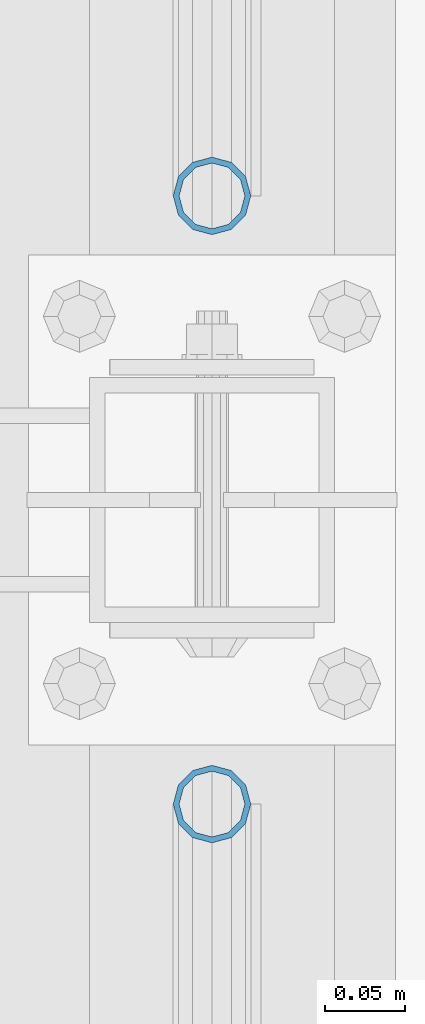
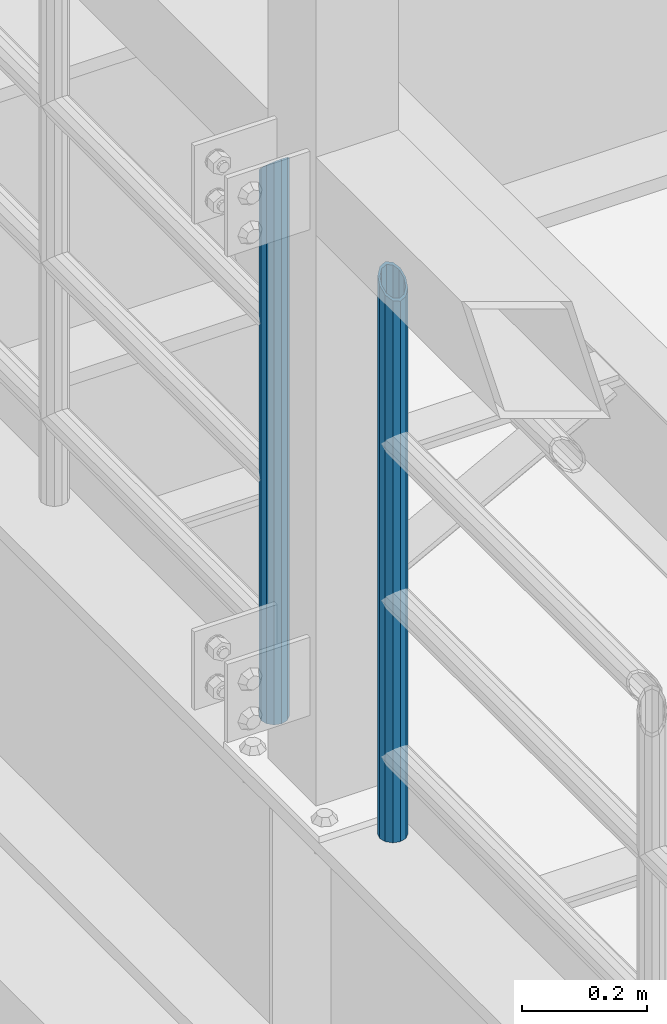
# One storey, part 681 of 1876: 2 columns, 2 elements without a shape of their own.
"""IFC2X3 building model written with IfcOpenShell, lengths in millimetres."""

from ifc_helpers import new_model, si_unit, frame, origin_with_axes, place, context, subcontext, project, spatial, faceted_brep, material, type_object, element, aggregate, save


model = new_model("IFC2X3")

# Units and contexts
model_context = context("Model", 3, precision=1e-05, world=origin_with_axes())
body_context = subcontext(model_context, "Body", "Model", "MODEL_VIEW")
ifc_project = project(units=[si_unit("LENGTHUNIT", "METRE", prefix="MILLI"), si_unit("AREAUNIT", "SQUARE_METRE"), si_unit("VOLUMEUNIT", "CUBIC_METRE"), si_unit("MASSUNIT", "GRAM", prefix="KILO"), si_unit("TIMEUNIT", "SECOND"), si_unit("PLANEANGLEUNIT", "RADIAN"), si_unit("SOLIDANGLEUNIT", "STERADIAN"), si_unit("THERMODYNAMICTEMPERATUREUNIT", "DEGREE_CELSIUS"), si_unit("LUMINOUSINTENSITYUNIT", "LUMEN")], contexts=[model_context])

# Site, building, storey
site_placement = place(None, origin_with_axes())
site = spatial("IfcSite", under=ifc_project, at=site_placement, CompositionType="ELEMENT")
building_placement = place(site_placement, origin_with_axes())
building = spatial("IfcBuilding", under=site, at=building_placement, Name="Undefined", CompositionType="ELEMENT")
storey_placement = place(building_placement, origin_with_axes())
storey = spatial("IfcBuildingStorey", under=building, at=storey_placement, Name="Undefined", CompositionType="ELEMENT", Elevation=0.0)

# Assembly, column
assembly_1_placement = place(storey_placement, origin_with_axes())
assembly_1 = element("IfcElementAssembly", 1, at=assembly_1_placement, inside=storey, Name="RAIL", AssemblyPlace="NOTDEFINED", PredefinedType="RIGID_FRAME")
ifc_material = material()
column_type = type_object("IfcColumnType", Name="PIPE1-1/2SCH40", PredefinedType="NOTDEFINED")
column_1_placement = place(assembly_1_placement, frame((-1.81898940354586e-12, -318.77, 5130.8), z_axis=(0.0, 1.0, 0.0), x_axis=(0.0, 0.0, 1.0)))
column_1 = element("IfcColumn", 2, at=column_1_placement, type_object=column_type, material=ifc_material, Name="POST", ObjectType="PIPE1-1/2SCH40", context=body_context, shape_type="Brep", body=[
    faceted_brep([(0.0, -20.4469999999999, 0.0), (0.0, -17.7076214311803, 10.2235000000001), (1066.10158618498, -17.7076214311801, 10.2235000000001), (1076.325, -20.4469999999999, 0.0), (0.0, -10.2235000000001, 17.7076214311801), (1058.61752784562, -10.2235000000001, 17.7076214311801), (-1.45519152283669e-11, 0.0, 20.4470000000001), (1055.87817237002, 0.0, 20.4470000000001), (0.0, 10.2235000000001, 17.7076214311801), (1058.61752784562, 10.2235000000001, 17.7076214311801), (0.0, 17.7076214311803, 10.2235000000001), (1066.10158618498, 17.7076214311801, 10.2235000000001), (0.0, 20.4469999999999, 0.0), (1076.325, 20.4469999999999, 0.0), (0.0, 17.7076214311803, -10.2235000000001), (1086.54841381489, 17.7076214311801, -10.2235000000001), (0.0, 10.2235000000001, -17.7076214311801), (1094.03247215425, 10.2235000000001, -17.7076214311801), (-1.45519152283669e-11, 0.0, -20.4470000000001), (1096.77182762985, 0.0, -20.4470000000001), (0.0, -10.2235000000001, -17.7076214311801), (1094.03247215425, -10.2235000000001, -17.7076214311801), (0.0, -17.7076214311803, -10.2235000000001), (1086.54841381489, -17.7076214311801, -10.2235000000001), (0.0, -24.1299999999992, 0.0), (0.0, -20.8971929933184, -12.0649999999996), (1088.38989829088, -20.8971929933186, -12.0649999999996), (1076.325, -24.1300000000001, 0.0), (0.0, -12.0650000000001, -20.8971929933186), (1097.222016828, -12.0649999999996, -20.8971929933186), (-1.45519152283669e-11, 0.0, -24.130000000001), (1100.45479658183, 0.0, -24.1300000000001), (0.0, 12.0650000000001, -20.8971929933186), (1097.222016828, 12.0649999999996, -20.8971929933186), (0.0, 20.8971929933184, -12.0649999999996), (1088.38989829088, 20.8971929933186, -12.0649999999996), (0.0, 24.1299999999992, 0.0), (1076.325, 24.1300000000001, 0.0), (0.0, 20.8971929933184, 12.0649999999996), (1064.26010170542, 20.8971929933186, 12.0650000000001), (0.0, 12.0650000000001, 20.8971929933186), (1055.42798316718, 12.0649999999996, 20.8971929933186), (-1.45519152283669e-11, 0.0, 24.130000000001), (1052.19520341295, 0.0, 24.1300000000001), (0.0, -12.0650000000001, 20.8971929933186), (1055.42798316718, -12.0649999999996, 20.8971929933186), (0.0, -20.8971929933184, 12.0649999999996), (1064.26010170542, -20.8971929933186, 12.0650000000001)], [[[0, 1, 2, 3]], [[1, 4, 5, 2]], [[4, 6, 7, 5]], [[6, 8, 9, 7]], [[8, 10, 11, 9]], [[10, 12, 13, 11]], [[12, 14, 15, 13]], [[14, 16, 17, 15]], [[16, 18, 19, 17]], [[18, 20, 21, 19]], [[20, 22, 23, 21]], [[22, 0, 3, 23]], [[24, 25, 26, 27]], [[25, 28, 29, 26]], [[28, 30, 31, 29]], [[30, 32, 33, 31]], [[32, 34, 35, 33]], [[34, 36, 37, 35]], [[36, 38, 39, 37]], [[38, 40, 41, 39]], [[40, 42, 43, 41]], [[42, 44, 45, 43]], [[44, 46, 47, 45]], [[46, 24, 27, 47]], [[29, 31, 33, 35, 37, 39, 41, 43, 45, 47, 27, 26], [5, 7, 9, 11, 13, 15, 17, 19, 21, 23, 3, 2]], [[46, 44, 42, 40, 38, 36, 34, 32, 30, 28, 25, 24], [22, 20, 18, 16, 14, 12, 10, 8, 6, 4, 1, 0]]]),
])
aggregate(assembly_1, [column_1])

assembly_2_placement = place(storey_placement, origin_with_axes())
assembly_2 = element("IfcElementAssembly", 3, at=assembly_2_placement, inside=storey, Name="RAIL", AssemblyPlace="NOTDEFINED", PredefinedType="RIGID_FRAME")
column_2_placement = place(assembly_2_placement, frame((-1.81898940354586e-12, -697.230000000001, 5130.8), z_axis=(0.0, 1.0, 0.0), x_axis=(0.0, 0.0, 1.0)))
column_2 = element("IfcColumn", 4, at=column_2_placement, type_object=column_type, material=ifc_material, Name="POST", ObjectType="PIPE1-1/2SCH40", context=body_context, shape_type="Brep", body=[
    faceted_brep([(0.0, -20.4469999999999, 0.0), (0.0, -17.7076214311803, 10.2235000000001), (1086.54849999999, -17.7076214311801, 10.2235000000001), (1076.325, -20.4469999999999, 0.0), (0.0, -10.2235000000001, 17.7076214311801), (1094.03262143117, -10.2235000000001, 17.7076214311801), (-1.45519152283669e-11, 0.0, 20.4470000000001), (1096.77199999999, 0.0, 20.4470000000001), (0.0, 10.2235000000001, 17.7076214311801), (1094.03262143117, 10.2235000000001, 17.7076214311801), (0.0, 17.7076214311803, 10.2235000000001), (1086.54849999999, 17.7076214311801, 10.2235000000001), (0.0, 20.4469999999999, 0.0), (1076.325, 20.4469999999999, 0.0), (0.0, 17.7076214311803, -10.2235000000001), (1066.10149999999, 17.7076214311801, -10.2235000000001), (0.0, 10.2235000000001, -17.7076214311801), (1058.61737856881, 10.2235000000001, -17.7076214311801), (-1.45519152283669e-11, 0.0, -20.4470000000001), (1055.87799999999, 0.0, -20.4470000000001), (0.0, -10.2235000000001, -17.7076214311801), (1058.61737856881, -10.2235000000001, -17.7076214311801), (0.0, -17.7076214311803, -10.2235000000001), (1066.10149999999, -17.7076214311801, -10.2235000000001), (0.0, -24.1299999999992, 0.0), (0.0, -20.8971929933184, -12.0649999999996), (1064.25999999999, -20.8971929933186, -12.0649999999996), (1076.325, -24.1300000000001, 0.0), (0.0, -12.0650000000001, -20.8971929933186), (1055.42780700667, -12.0649999999996, -20.8971929933186), (-1.45519152283669e-11, 0.0, -24.130000000001), (1052.19499999999, 0.0, -24.1300000000001), (0.0, 12.0650000000001, -20.8971929933186), (1055.42780700667, 12.0649999999996, -20.8971929933186), (0.0, 20.8971929933184, -12.0649999999996), (1064.25999999999, 20.8971929933186, -12.0649999999996), (0.0, 24.1299999999992, 0.0), (1076.325, 24.1300000000001, 0.0), (0.0, 20.8971929933184, 12.0649999999996), (1088.38999999999, 20.8971929933186, 12.0649999999996), (0.0, 12.0650000000001, 20.8971929933186), (1097.22219299331, 12.0649999999996, 20.8971929933186), (-1.45519152283669e-11, 0.0, 24.130000000001), (1100.45499999999, 0.0, 24.1300000000001), (0.0, -12.0650000000001, 20.8971929933186), (1097.22219299331, -12.0649999999996, 20.8971929933186), (0.0, -20.8971929933184, 12.0649999999996), (1088.38999999999, -20.8971929933186, 12.0649999999996)], [[[0, 1, 2, 3]], [[1, 4, 5, 2]], [[4, 6, 7, 5]], [[6, 8, 9, 7]], [[8, 10, 11, 9]], [[10, 12, 13, 11]], [[12, 14, 15, 13]], [[14, 16, 17, 15]], [[16, 18, 19, 17]], [[18, 20, 21, 19]], [[20, 22, 23, 21]], [[22, 0, 3, 23]], [[24, 25, 26, 27]], [[25, 28, 29, 26]], [[28, 30, 31, 29]], [[30, 32, 33, 31]], [[32, 34, 35, 33]], [[34, 36, 37, 35]], [[36, 38, 39, 37]], [[38, 40, 41, 39]], [[40, 42, 43, 41]], [[42, 44, 45, 43]], [[44, 46, 47, 45]], [[46, 24, 27, 47]], [[29, 31, 33, 35, 37, 39, 41, 43, 45, 47, 27, 26], [5, 7, 9, 11, 13, 15, 17, 19, 21, 23, 3, 2]], [[46, 44, 42, 40, 38, 36, 34, 32, 30, 28, 25, 24], [22, 20, 18, 16, 14, 12, 10, 8, 6, 4, 1, 0]]]),
])
aggregate(assembly_2, [column_2])

save(model, "model.ifc")
